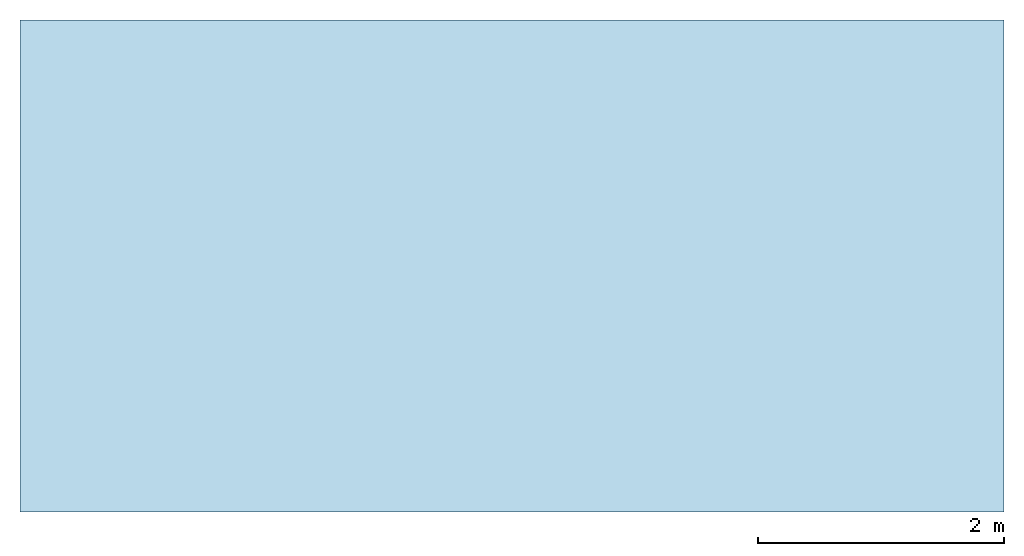
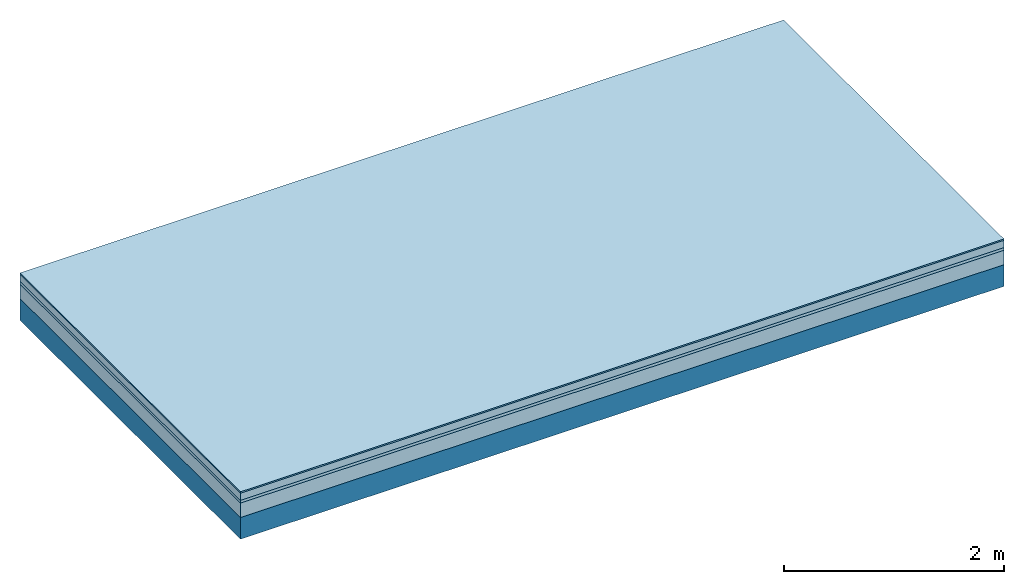
# One storey: 4 plates, 1 member, 1 element without a shape of its own.
"""IFC4 building model written with IfcOpenShell, lengths in metres."""

import ifcopenshell
import ifcopenshell.guid

model = None  # the IFC model being written
_history = None  # IfcOwnerHistory: only IFC2X3 demands one
_inside = {}  # id of a spatial element -> (the spatial element, [elements in it])
_under = {}  # id of a project, library or spatial element -> (it, [spatial elements below it])
_declared = {}  # id of a project -> (the project, [libraries it declares])
_typed = {}  # id of a type object -> (the type object, [elements of that type])
_made_of = {}  # id of a material, layer set ... -> (it, [elements and type objects made of it])


def new_model(schema):
    """Start an empty IFC model of exactly this schema.

    Asked for "IFC4X3", IfcOpenShell would pick the latest addendum, in which some entities
    have other attributes; the version numbers below select the first issue.
    IFC2X3 requires an IfcOwnerHistory on every rooted entity: one is made here for all.
    """
    global model, _history
    if schema == "IFC4X3":
        model = ifcopenshell.file(schema_version=(4, 3, 0, 0))
    else:
        model = ifcopenshell.file(schema=schema)
    _inside.clear()
    _under.clear()
    _declared.clear()
    _typed.clear()
    _made_of.clear()
    _history = None
    if model.schema == "IFC2X3":
        org = make("IfcOrganization", Name="unknown")
        user = make(
            "IfcPersonAndOrganization",
            ThePerson=make("IfcPerson", FamilyName="unknown"),
            TheOrganization=org,
        )
        app = make(
            "IfcApplication",
            ApplicationDeveloper=org,
            Version="unknown",
            ApplicationFullName="unknown",
            ApplicationIdentifier="unknown",
        )
        _history = make(
            "IfcOwnerHistory",
            OwningUser=user,
            OwningApplication=app,
            ChangeAction="ADDED",
            CreationDate=0,
        )
    return model


def make(cls, **values):
    """One entity of the class cls with the attributes given. An attribute that is None is left unset."""
    return model.create_entity(
        cls, **{name: value for name, value in values.items() if value is not None}
    )


def rooted(cls, **values):
    """An entity with a GlobalId (a new one), such as an element, a storey or a relation."""
    return make(cls, GlobalId=ifcopenshell.guid.new(), OwnerHistory=_history, **values)


def si_unit(unit_type, name, prefix=None):
    """IfcSIUnit, for example si_unit("LENGTHUNIT", "METRE", prefix="MILLI")."""
    return make("IfcSIUnit", UnitType=unit_type, Prefix=prefix, Name=name)


def derived_unit(unit_type, elements):
    """IfcDerivedUnit: a product of units, each with its exponent."""
    return make(
        "IfcDerivedUnit",
        Elements=[
            make("IfcDerivedUnitElement", Unit=unit, Exponent=power)
            for unit, power in elements
        ],
        UnitType=unit_type,
    )


def assignment(units):
    """IfcUnitAssignment: the units of a project."""
    return None if units is None else make("IfcUnitAssignment", Units=units)


def point(xyz):
    """IfcCartesianPoint."""
    return None if xyz is None else make("IfcCartesianPoint", Coordinates=xyz)


def direction(xyz):
    """IfcDirection."""
    return None if xyz is None else make("IfcDirection", DirectionRatios=xyz)


def frame(location, z_axis=None, x_axis=None):
    """IfcAxis2Placement3D, a coordinate frame: its origin and axes. An axis left out is left unset."""
    return make(
        "IfcAxis2Placement3D",
        Location=point(location),
        Axis=direction(z_axis),
        RefDirection=direction(x_axis),
    )


def frame_2d(location, x_axis=None):
    """IfcAxis2Placement2D, a coordinate frame in the plane: its origin and x axis."""
    return make(
        "IfcAxis2Placement2D", Location=point(location), RefDirection=direction(x_axis)
    )


def origin():
    """The frame at (0, 0, 0) with its axes left unset."""
    return frame((0.0, 0.0, 0.0))


def origin_with_axes():
    """The frame at (0, 0, 0) with the z axis (0, 0, 1) and the x axis (1, 0, 0) written out."""
    return frame((0.0, 0.0, 0.0), z_axis=(0.0, 0.0, 1.0), x_axis=(1.0, 0.0, 0.0))


def place(relative_to, where):
    """IfcLocalPlacement: puts the frame where relative to a parent placement (None: the world)."""
    return make(
        "IfcLocalPlacement", PlacementRelTo=relative_to, RelativePlacement=where
    )


def context(
    kind, dimensions, precision=None, world=None, true_north=None, identifier=None
):
    """IfcGeometricRepresentationContext, for example the 3D "Model" context."""
    return make(
        "IfcGeometricRepresentationContext",
        ContextIdentifier=identifier,
        ContextType=kind,
        CoordinateSpaceDimension=dimensions,
        Precision=precision,
        WorldCoordinateSystem=world,
        TrueNorth=true_north,
    )


def project(units=None, contexts=None):
    """IfcProject with its units and contexts."""
    return rooted(
        "IfcProject",
        Name="project",
        RepresentationContexts=contexts,
        UnitsInContext=assignment(units),
    )


def spatial(cls, under=None, at=None, **own):
    """A site, building, storey or space (cls), placed at a placement, below another one or the project."""
    s = rooted(cls, ObjectPlacement=at, **own)
    if under is not None:
        _under.setdefault(under.id(), (under, []))[1].append(s)
    return s


def profile(cls, at=None, kind="AREA", **sizes):
    """A parametric profile (cls). Its sizes go by their IFC names, for example OverallWidth=200.0."""
    return make(cls, ProfileType=kind, Position=at, **sizes)


def rectangle(**sizes):
    """IfcRectangleProfileDef."""
    return profile("IfcRectangleProfileDef", **sizes)


def extrude(swept, where, along, depth):
    """IfcExtrudedAreaSolid: the profile swept, set in the frame where, extruded along a direction by depth."""
    return make(
        "IfcExtrudedAreaSolid",
        SweptArea=swept,
        Position=where,
        ExtrudedDirection=direction(along),
        Depth=depth,
    )


def shape(context_of_items, identifier, shape_type, items):
    """IfcShapeRepresentation: the items that make up one representation, for example the "Body"."""
    return make(
        "IfcShapeRepresentation",
        ContextOfItems=context_of_items,
        RepresentationIdentifier=identifier,
        RepresentationType=shape_type,
        Items=items,
    )


def material(Name=None, Category=None):
    """IfcMaterial."""
    return make("IfcMaterial", Name=Name, Category=Category)


def layer(
    of_material, thickness, ventilated=None, Name=None, Category=None, Priority=None
):
    """IfcMaterialLayer: one layer of a wall or slab, of a material (None: an air gap)."""
    return make(
        "IfcMaterialLayer",
        Material=of_material,
        LayerThickness=thickness,
        IsVentilated=ventilated,
        Name=Name,
        Category=Category,
        Priority=Priority,
    )


def layer_set(layers, Name=None):
    """IfcMaterialLayerSet."""
    return make("IfcMaterialLayerSet", MaterialLayers=layers, LayerSetName=Name)


def made_of(thing, what):
    """Note that an element or type object is made of a material, layer set ...; save() writes the relation."""
    if what is not None:
        _made_of.setdefault(what.id(), (what, []))[1].append(thing)
    return thing


def type_object(cls, material=None, **own):
    """A type object (cls), such as IfcWallType, which elements share."""
    return made_of(rooted(cls, **own), material)


def element(
    cls,
    number,
    at=None,
    inside=None,
    cuts=None,
    type_object=None,
    material=None,
    context=None,
    identifier="Body",
    shape_type=None,
    held_by="IfcProductDefinitionShape",
    body=None,
    shapes=None,
    **own,
):
    """One element of the class cls, such as IfcWall. Its Tag is "e" and its number.

    at: its placement. inside: the storey or other place that contains it. cuts: it is an
    opening in that element (IfcRelVoidsElement). A single representation is given by context,
    identifier, shape_type and body (its items); several are given by shapes. held_by: the class
    of the entity that holds the representations. save() writes the other relations.
    """
    e = rooted(cls, Tag="e%d" % number, ObjectPlacement=at, **own)
    if body is not None:
        shapes = [shape(context, identifier, shape_type, body)]
    if shapes is not None:
        e.Representation = make(held_by, Representations=shapes)
    if inside is not None:
        _inside.setdefault(inside.id(), (inside, []))[1].append(e)
    if cuts is not None:
        rooted(
            "IfcRelVoidsElement", RelatingBuildingElement=cuts, RelatedOpeningElement=e
        )
    if type_object is not None:
        _typed.setdefault(type_object.id(), (type_object, []))[1].append(e)
    return made_of(e, material)


def aggregate(whole, parts):
    """IfcRelAggregates: a whole, such as a stair, and the parts it consists of."""
    return rooted("IfcRelAggregates", RelatingObject=whole, RelatedObjects=parts)


def save(model, path):
    """Write the relations noted so far, then the file.

    IfcRelAggregates (storeys below a building ...), IfcRelContainedInSpatialStructure (elements
    in a storey), IfcRelDefinesByType, IfcRelAssociatesMaterial and IfcRelDeclares: one each for
    every whole, place, type object, material and project.
    """
    for whole, parts in _under.values():
        aggregate(whole, parts)
    for where, things in _inside.values():
        rooted(
            "IfcRelContainedInSpatialStructure",
            RelatedElements=things,
            RelatingStructure=where,
        )
    for kind, things in _typed.values():
        rooted("IfcRelDefinesByType", RelatedObjects=things, RelatingType=kind)
    for what, things in _made_of.values():
        rooted("IfcRelAssociatesMaterial", RelatedObjects=things, RelatingMaterial=what)
    for by, libraries in _declared.values():
        rooted("IfcRelDeclares", RelatingContext=by, RelatedDefinitions=libraries)
    model.write(path)


model = new_model("IFC4")

# Units and contexts
plan_context = context("Plan", 3, precision=1e-05, world=origin(), true_north=direction((0.0, 1.0)))
model_context = context("Model", 3, precision=1e-05, world=origin(), true_north=direction((0.0, 1.0)))
ifc_project = project(units=[si_unit("LENGTHUNIT", "METRE"), derived_unit("SOUNDPRESSUREUNIT", [(si_unit("PRESSUREUNIT", "PASCAL", prefix="MICRO"), 0)]), si_unit("ENERGYUNIT", "JOULE", prefix="MEGA"), si_unit("MASSUNIT", "GRAM", prefix="KILO"), derived_unit("THERMALTRANSMITTANCEUNIT", [(si_unit("POWERUNIT", "WATT"), 1), (si_unit("AREAUNIT", "SQUARE_METRE"), -1), (si_unit("THERMODYNAMICTEMPERATUREUNIT", "KELVIN"), -1)]), derived_unit("AREADENSITYUNIT", [(si_unit("MASSUNIT", "GRAM", prefix="KILO"), 1), (si_unit("AREAUNIT", "SQUARE_METRE"), -1)]), derived_unit("USERDEFINED", [(si_unit("ENERGYUNIT", "JOULE", prefix="MEGA"), 1), (si_unit("AREAUNIT", "SQUARE_METRE"), -1)])], contexts=[plan_context, model_context])

# Site, building, storey
site = spatial("IfcSite", under=ifc_project)
building_placement = place(None, origin())
building = spatial("IfcBuilding", under=site, at=building_placement)
storey_placement = place(building_placement, origin())
storey = spatial("IfcBuildingStorey", under=building, at=storey_placement)

# Slab, member, plates
ifc_material_1 = material(Category="11.013")
ifc_layer_1 = layer(ifc_material_1, 0.015, Name="Flooring")
ifc_material_2 = material(Name="Cement screed", Category="04.006")
ifc_layer_2 = layer(ifc_material_2, 0.08, Name="On-material")
ifc_material_3 = material(Name="Wood fiber generic product", Category="10.009")
ifc_layer_3 = layer(ifc_material_3, 0.03, Name="Impact sound insulation")
ifc_material_4 = material(Category="01.002")
ifc_layer_4 = layer(ifc_material_4, 0.16, Name="Sub-floor")
ifc_material_5 = material(Name="Rigid, of the art")
ifc_layer_5 = layer(ifc_material_5, 0.0, Name="Bond")
ifc_layer_6 = layer(None, 0.24, Name="Supporting structure")
ifc_layer_set = layer_set([ifc_layer_1, ifc_layer_2, ifc_layer_3, ifc_layer_4, ifc_layer_5, ifc_layer_6])
slab_type = type_object("IfcSlabType", Name="A2215", PredefinedType="NOTDEFINED", material=ifc_layer_set)
slab_placement = place(None, frame((0.0, 0.0, 0.0), z_axis=(0.0, 0.0, -1.0), x_axis=(1.0, 0.0, 0.0)))
slab = element("IfcSlab", 1, at=slab_placement, inside=storey, type_object=slab_type, material=ifc_layer_set, Name="Slab #1")
ifc_material_6 = material(Name="Solid timber panel")
member_placement = place(slab_placement, origin())
member = element("IfcMember", 2, at=member_placement, material=ifc_material_6, Name="Supporting structure", context=plan_context, shape_type="SweptSolid", body=[
    extrude(rectangle(XDim=1.0, YDim=0.24, at=frame_2d((0.5, 0.12), x_axis=(1.0, 0.0))), frame((0.0, 4.0, 0.285), z_axis=(0.0, -1.0, 0.0), x_axis=(1.0, 0.0, 0.0)), (0.0, 0.0, 1.0), 4.0),
    extrude(rectangle(XDim=1.0, YDim=0.24, at=frame_2d((0.5, 0.12), x_axis=(1.0, 0.0))), frame((1.0, 4.0, 0.285), z_axis=(0.0, -1.0, 0.0), x_axis=(1.0, 0.0, 0.0)), (0.0, 0.0, 1.0), 4.0),
    extrude(rectangle(XDim=1.0, YDim=0.24, at=frame_2d((0.5, 0.12), x_axis=(1.0, 0.0))), frame((2.0, 4.0, 0.285), z_axis=(0.0, -1.0, 0.0), x_axis=(1.0, 0.0, 0.0)), (0.0, 0.0, 1.0), 4.0),
    extrude(rectangle(XDim=1.0, YDim=0.24, at=frame_2d((0.5, 0.12), x_axis=(1.0, 0.0))), frame((3.0, 4.0, 0.285), z_axis=(0.0, -1.0, 0.0), x_axis=(1.0, 0.0, 0.0)), (0.0, 0.0, 1.0), 4.0),
    extrude(rectangle(XDim=1.0, YDim=0.24, at=frame_2d((0.5, 0.12), x_axis=(1.0, 0.0))), frame((4.0, 4.0, 0.285), z_axis=(0.0, -1.0, 0.0), x_axis=(1.0, 0.0, 0.0)), (0.0, 0.0, 1.0), 4.0),
    extrude(rectangle(XDim=1.0, YDim=0.24, at=frame_2d((0.5, 0.12), x_axis=(1.0, 0.0))), frame((5.0, 4.0, 0.285), z_axis=(0.0, -1.0, 0.0), x_axis=(1.0, 0.0, 0.0)), (0.0, 0.0, 1.0), 4.0),
    extrude(rectangle(XDim=1.0, YDim=0.24, at=frame_2d((0.5, 0.12), x_axis=(1.0, 0.0))), frame((6.0, 4.0, 0.285), z_axis=(0.0, -1.0, 0.0), x_axis=(1.0, 0.0, 0.0)), (0.0, 0.0, 1.0), 4.0),
    extrude(rectangle(XDim=1.0, YDim=0.24, at=frame_2d((0.5, 0.12), x_axis=(1.0, 0.0))), frame((7.0, 4.0, 0.285), z_axis=(0.0, -1.0, 0.0), x_axis=(1.0, 0.0, 0.0)), (0.0, 0.0, 1.0), 4.0),
])
plate_1_placement = place(slab_placement, origin())
plate_1 = element("IfcPlate", 3, at=plate_1_placement, material=ifc_material_1, Name="Flooring", context=plan_context, shape_type="SweptSolid", body=[
    extrude(rectangle(XDim=8.0, YDim=4.0, at=frame_2d((4.0, 2.0), x_axis=(1.0, 0.0))), origin_with_axes(), (0.0, 0.0, 1.0), 0.015),
])
plate_2_placement = place(slab_placement, origin())
plate_2 = element("IfcPlate", 4, at=plate_2_placement, material=ifc_material_2, Name="On-material", context=plan_context, shape_type="SweptSolid", body=[
    extrude(rectangle(XDim=8.0, YDim=4.0, at=frame_2d((4.0, 2.0), x_axis=(1.0, 0.0))), frame((0.0, 0.0, 0.015), z_axis=(0.0, 0.0, 1.0), x_axis=(1.0, 0.0, 0.0)), (0.0, 0.0, 1.0), 0.08),
])
plate_3_placement = place(slab_placement, origin())
plate_3 = element("IfcPlate", 5, at=plate_3_placement, material=ifc_material_3, Name="Impact sound insulation", context=plan_context, shape_type="SweptSolid", body=[
    extrude(rectangle(XDim=8.0, YDim=4.0, at=frame_2d((4.0, 2.0), x_axis=(1.0, 0.0))), frame((0.0, 0.0, 0.095), z_axis=(0.0, 0.0, 1.0), x_axis=(1.0, 0.0, 0.0)), (0.0, 0.0, 1.0), 0.03),
])
plate_4_placement = place(slab_placement, origin())
plate_4 = element("IfcPlate", 6, at=plate_4_placement, material=ifc_material_4, Name="Sub-floor", context=plan_context, shape_type="SweptSolid", body=[
    extrude(rectangle(XDim=8.0, YDim=4.0, at=frame_2d((4.0, 2.0), x_axis=(1.0, 0.0))), frame((0.0, 0.0, 0.125), z_axis=(0.0, 0.0, 1.0), x_axis=(1.0, 0.0, 0.0)), (0.0, 0.0, 1.0), 0.16),
])
aggregate(slab, [plate_1, plate_2, plate_3, plate_4, member])

save(model, "model.ifc")
